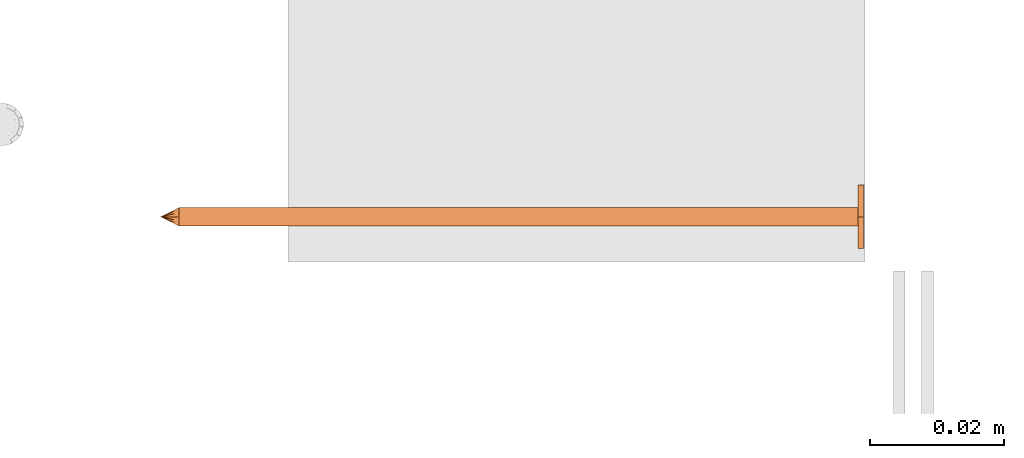
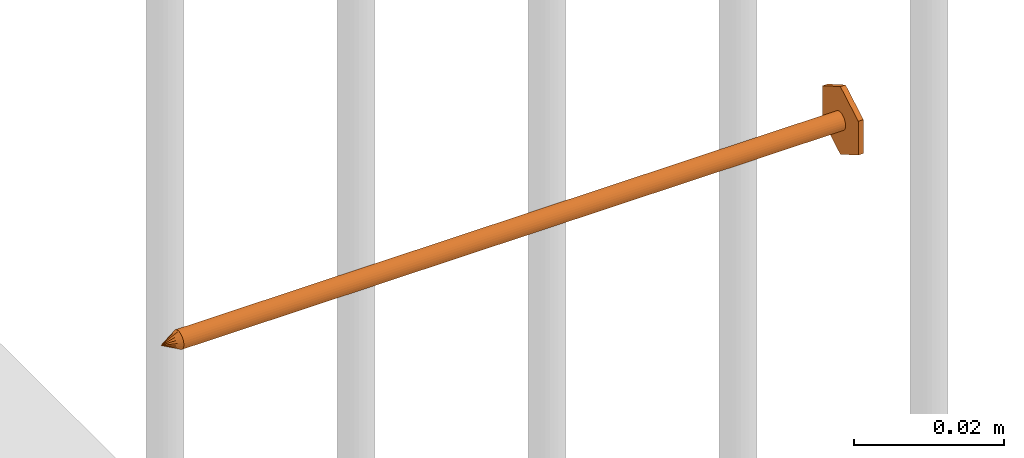
# One storey, part 22 of 44: 1 proxy.
"""IFC4 building model written with IfcOpenShell, lengths in feet."""

from ifc_helpers import new_model, entity, si_unit, converted_unit, derived_unit, direction, frame, origin, place, context, subcontext, project, spatial, source, transform, mapped, material, type_object, type_shapes, element, save


model = new_model("IFC4")

# Units and contexts
model_context = context("Model", 3, precision=0.0001, world=origin(), true_north=direction((6.12303176911189e-17, 1.0)))
body_context = subcontext(model_context, "Body", "Model", "MODEL_VIEW")
ifc_project = project(units=[converted_unit("LENGTHUNIT", "FOOT", entity("IfcRatioMeasure", 0.3048), si_unit("LENGTHUNIT", "METRE"), dimensions=[1, 0, 0, 0, 0, 0, 0]), converted_unit("AREAUNIT", "SQUARE FOOT", entity("IfcRatioMeasure", 0.09290304), si_unit("AREAUNIT", "SQUARE_METRE"), dimensions=[2, 0, 0, 0, 0, 0, 0]), converted_unit("VOLUMEUNIT", "CUBIC FOOT", entity("IfcRatioMeasure", 0.028316846592), si_unit("VOLUMEUNIT", "CUBIC_METRE"), dimensions=[3, 0, 0, 0, 0, 0, 0]), converted_unit("PLANEANGLEUNIT", "DEGREE", entity("IfcRatioMeasure", 0.0174532925199433), si_unit("PLANEANGLEUNIT", "RADIAN"), dimensions=[0, 0, 0, 0, 0, 0, 0]), si_unit("MASSUNIT", "GRAM", prefix="KILO"), derived_unit("MASSDENSITYUNIT", [(si_unit("MASSUNIT", "GRAM", prefix="KILO"), 1), (si_unit("LENGTHUNIT", "METRE"), -3)]), derived_unit("MOMENTOFINERTIAUNIT", [(si_unit("LENGTHUNIT", "METRE"), 4)]), si_unit("TIMEUNIT", "SECOND"), si_unit("FREQUENCYUNIT", "HERTZ"), si_unit("THERMODYNAMICTEMPERATUREUNIT", "DEGREE_CELSIUS"), derived_unit("THERMALTRANSMITTANCEUNIT", [(si_unit("MASSUNIT", "GRAM", prefix="KILO"), 1), (si_unit("THERMODYNAMICTEMPERATUREUNIT", "KELVIN"), -1), (si_unit("TIMEUNIT", "SECOND"), -3)]), derived_unit("VOLUMETRICFLOWRATEUNIT", [(si_unit("LENGTHUNIT", "METRE"), 3), (si_unit("TIMEUNIT", "SECOND"), -1)]), si_unit("ELECTRICCURRENTUNIT", "AMPERE"), si_unit("ELECTRICVOLTAGEUNIT", "VOLT"), si_unit("POWERUNIT", "WATT"), si_unit("FORCEUNIT", "NEWTON"), si_unit("ILLUMINANCEUNIT", "LUX"), si_unit("LUMINOUSFLUXUNIT", "LUMEN"), si_unit("LUMINOUSINTENSITYUNIT", "CANDELA"), derived_unit("USERDEFINED", [(si_unit("MASSUNIT", "GRAM", prefix="KILO"), -1), (si_unit("LENGTHUNIT", "METRE"), -2), (si_unit("TIMEUNIT", "SECOND"), 3), (si_unit("LUMINOUSFLUXUNIT", "LUMEN"), 1)]), derived_unit("LINEARVELOCITYUNIT", [(si_unit("LENGTHUNIT", "METRE"), 1), (si_unit("TIMEUNIT", "SECOND"), -1)]), si_unit("PRESSUREUNIT", "PASCAL"), derived_unit("USERDEFINED", [(si_unit("LENGTHUNIT", "METRE"), -2), (si_unit("MASSUNIT", "GRAM", prefix="KILO"), 1), (si_unit("TIMEUNIT", "SECOND"), -2)]), derived_unit("LINEARFORCEUNIT", [(si_unit("MASSUNIT", "GRAM", prefix="KILO"), 1), (si_unit("LENGTHUNIT", "METRE"), 1), (si_unit("TIMEUNIT", "SECOND"), -2), (si_unit("LENGTHUNIT", "METRE"), -1)]), derived_unit("PLANARFORCEUNIT", [(si_unit("MASSUNIT", "GRAM", prefix="KILO"), 1), (si_unit("LENGTHUNIT", "METRE"), 1), (si_unit("TIMEUNIT", "SECOND"), -2), (si_unit("LENGTHUNIT", "METRE"), -2)])], contexts=[model_context])

# Site, building, storey
site_placement = place(None, origin())
site = spatial("IfcSite", under=ifc_project, at=site_placement, CompositionType="ELEMENT")
building_placement = place(site_placement, origin())
building = spatial("IfcBuilding", under=site, at=building_placement, CompositionType="ELEMENT")
storey_placement = place(building_placement, origin())
storey = spatial("IfcBuildingStorey", under=building, at=storey_placement, CompositionType="ELEMENT", Elevation=0.0)

# Proxy
ifc_material = material(Category="Materials")
building_element_proxy_type = type_object("IfcBuildingElementProxyType", PredefinedType="NOTDEFINED", material=ifc_material)
cartesian_point_1 = entity("IfcCartesianPoint", [0.0, -0.00455729166677942, -0.333333333333231])
vertex_point_1 = entity("IfcVertexPoint", cartesian_point_1)
cartesian_point_2 = entity("IfcCartesianPoint", [0.0, 0.00455729166667798, -0.333333333333232])
vertex_point_2 = entity("IfcVertexPoint", cartesian_point_2)
cartesian_point_3 = entity("IfcCartesianPoint", [0.0, 0.0, -0.333333333333232])
ifc_direction_1 = entity("IfcDirection", [0.0, 0.0, 1.0])
ifc_direction_2 = entity("IfcDirection", [0.0, 1.0, 0.0])
edge_curve_1 = entity("IfcEdgeCurve", vertex_point_1, vertex_point_2, entity("IfcTrimmedCurve", entity("IfcCircle", entity("IfcAxis2Placement3D", cartesian_point_3, ifc_direction_1, ifc_direction_2), 0.0045572916667287), [cartesian_point_1], [cartesian_point_2], True, "CARTESIAN"), True)
vertex_point_3 = entity("IfcVertexPoint", cartesian_point_3)
ifc_direction_3 = entity("IfcDirection", [0.0, -1.0, 0.0])
edge_curve_2 = entity("IfcEdgeCurve", vertex_point_2, vertex_point_3, entity("IfcTrimmedCurve", entity("IfcLine", cartesian_point_2, entity("IfcVector", ifc_direction_3, 1.0)), [cartesian_point_2], [cartesian_point_3], True, "CARTESIAN"), True)
edge_curve_3 = entity("IfcEdgeCurve", vertex_point_3, vertex_point_1, entity("IfcTrimmedCurve", entity("IfcLine", cartesian_point_3, entity("IfcVector", ifc_direction_3, 1.0)), [cartesian_point_3], [cartesian_point_1], True, "CARTESIAN"), True)
edge_curve_4 = entity("IfcEdgeCurve", vertex_point_2, vertex_point_1, entity("IfcTrimmedCurve", entity("IfcCircle", entity("IfcAxis2Placement3D", cartesian_point_3, ifc_direction_1, ifc_direction_2), 0.0045572916667287), [cartesian_point_2], [cartesian_point_1], True, "CARTESIAN"), True)
cartesian_point_4 = entity("IfcCartesianPoint", [0.0, 0.0, -0.342447916666333])
vertex_point_4 = entity("IfcVertexPoint", cartesian_point_4)
edge_curve_5 = entity("IfcEdgeCurve", vertex_point_4, vertex_point_2, entity("IfcTrimmedCurve", entity("IfcLine", cartesian_point_4, entity("IfcVector", entity("IfcDirection", [0.0, 0.447213595514596, 0.894427190992597]), 1.0)), [cartesian_point_4], [cartesian_point_2], True, "CARTESIAN"), True)
edge_curve_6 = entity("IfcEdgeCurve", vertex_point_1, vertex_point_4, entity("IfcTrimmedCurve", entity("IfcLine", cartesian_point_1, entity("IfcVector", entity("IfcDirection", [0.0, 0.447213595514579, -0.894427190992605]), 1.0)), [cartesian_point_1], [cartesian_point_4], True, "CARTESIAN"), True)
cartesian_point_5 = entity("IfcCartesianPoint", [-0.00455729166669724, 0.0, -0.333333333333231])
cartesian_point_6 = entity("IfcCartesianPoint", [0.0, 0.0, -0.338202184590857])
ifc_direction_4 = entity("IfcDirection", [0.0, 0.0, -1.0])
cartesian_point_7 = entity("IfcCartesianPoint", [-0.0156249999999625, 0.00902109795594613, 0.00260416666704037])
vertex_point_5 = entity("IfcVertexPoint", cartesian_point_7)
cartesian_point_8 = entity("IfcCartesianPoint", [-0.0156249999999625, -0.0090210979562493, 0.00260416666704046])
vertex_point_6 = entity("IfcVertexPoint", cartesian_point_8)
ifc_direction_5 = entity("IfcDirection", [0.0, -1.0, 0.0])
edge_curve_7 = entity("IfcEdgeCurve", vertex_point_5, vertex_point_6, entity("IfcTrimmedCurve", entity("IfcLine", cartesian_point_7, entity("IfcVector", ifc_direction_5, 1.0)), [cartesian_point_7], [cartesian_point_8], True, "CARTESIAN"), True)
cartesian_point_9 = entity("IfcCartesianPoint", [0.0, -0.0180421959123274, 0.0026041666670405])
vertex_point_7 = entity("IfcVertexPoint", cartesian_point_9)
edge_curve_8 = entity("IfcEdgeCurve", vertex_point_6, vertex_point_7, entity("IfcTrimmedCurve", entity("IfcLine", cartesian_point_8, entity("IfcVector", entity("IfcDirection", [0.866025403784438, -0.500000000000001, 0.0]), 1.0)), [cartesian_point_8], [cartesian_point_9], True, "CARTESIAN"), True)
cartesian_point_10 = entity("IfcCartesianPoint", [0.0156250000000786, -0.00902109795620598, 0.00260416666704046])
vertex_point_8 = entity("IfcVertexPoint", cartesian_point_10)
edge_curve_9 = entity("IfcEdgeCurve", vertex_point_7, vertex_point_8, entity("IfcTrimmedCurve", entity("IfcLine", cartesian_point_9, entity("IfcVector", entity("IfcDirection", [0.86602540378444, 0.499999999999998, 0.0]), 1.0)), [cartesian_point_9], [cartesian_point_10], True, "CARTESIAN"), True)
cartesian_point_11 = entity("IfcCartesianPoint", [0.0156250000000786, 0.00902109795590273, 0.00260416666704037])
vertex_point_9 = entity("IfcVertexPoint", cartesian_point_11)
ifc_direction_6 = entity("IfcDirection", [0.0, 1.0, 0.0])
edge_curve_10 = entity("IfcEdgeCurve", vertex_point_8, vertex_point_9, entity("IfcTrimmedCurve", entity("IfcLine", cartesian_point_10, entity("IfcVector", ifc_direction_6, 1.0)), [cartesian_point_10], [cartesian_point_11], True, "CARTESIAN"), True)
cartesian_point_12 = entity("IfcCartesianPoint", [0.0, 0.0180421959120243, 0.00260416666704032])
vertex_point_10 = entity("IfcVertexPoint", cartesian_point_12)
edge_curve_11 = entity("IfcEdgeCurve", vertex_point_9, vertex_point_10, entity("IfcTrimmedCurve", entity("IfcLine", cartesian_point_11, entity("IfcVector", entity("IfcDirection", [-0.866025403784437, 0.500000000000003, 0.0]), 1.0)), [cartesian_point_11], [cartesian_point_12], True, "CARTESIAN"), True)
edge_curve_12 = entity("IfcEdgeCurve", vertex_point_10, vertex_point_5, entity("IfcTrimmedCurve", entity("IfcLine", cartesian_point_12, entity("IfcVector", entity("IfcDirection", [-0.866025403784438, -0.500000000000001, 0.0]), 1.0)), [cartesian_point_12], [cartesian_point_7], True, "CARTESIAN"), True)
ifc_direction_7 = entity("IfcDirection", [0.0, 0.0, 1.0])
cartesian_point_13 = entity("IfcCartesianPoint", [-0.0156249999999625, 0.00902109795594612, 0.0])
vertex_point_11 = entity("IfcVertexPoint", cartesian_point_13)
cartesian_point_14 = entity("IfcCartesianPoint", [0.0, 0.0180421959120242, 0.0])
vertex_point_12 = entity("IfcVertexPoint", cartesian_point_14)
edge_curve_13 = entity("IfcEdgeCurve", vertex_point_11, vertex_point_12, entity("IfcTrimmedCurve", entity("IfcLine", cartesian_point_13, entity("IfcVector", entity("IfcDirection", [0.866025403784438, 0.500000000000001, 0.0]), 1.0)), [cartesian_point_13], [cartesian_point_14], True, "CARTESIAN"), True)
cartesian_point_15 = entity("IfcCartesianPoint", [0.0156250000000786, 0.00902109795590272, 0.0])
vertex_point_13 = entity("IfcVertexPoint", cartesian_point_15)
edge_curve_14 = entity("IfcEdgeCurve", vertex_point_12, vertex_point_13, entity("IfcTrimmedCurve", entity("IfcLine", cartesian_point_14, entity("IfcVector", entity("IfcDirection", [0.866025403784437, -0.500000000000003, 0.0]), 1.0)), [cartesian_point_14], [cartesian_point_15], True, "CARTESIAN"), True)
cartesian_point_16 = entity("IfcCartesianPoint", [0.0156250000000786, -0.00902109795620599, 0.0])
vertex_point_14 = entity("IfcVertexPoint", cartesian_point_16)
edge_curve_15 = entity("IfcEdgeCurve", vertex_point_13, vertex_point_14, entity("IfcTrimmedCurve", entity("IfcLine", cartesian_point_15, entity("IfcVector", ifc_direction_5, 1.0)), [cartesian_point_15], [cartesian_point_16], True, "CARTESIAN"), True)
cartesian_point_17 = entity("IfcCartesianPoint", [0.0, -0.0180421959123274, 0.0])
vertex_point_15 = entity("IfcVertexPoint", cartesian_point_17)
edge_curve_16 = entity("IfcEdgeCurve", vertex_point_14, vertex_point_15, entity("IfcTrimmedCurve", entity("IfcLine", cartesian_point_16, entity("IfcVector", entity("IfcDirection", [-0.86602540378444, -0.499999999999998, 0.0]), 1.0)), [cartesian_point_16], [cartesian_point_17], True, "CARTESIAN"), True)
cartesian_point_18 = entity("IfcCartesianPoint", [-0.0156249999999625, -0.00902109795624931, 0.0])
vertex_point_16 = entity("IfcVertexPoint", cartesian_point_18)
edge_curve_17 = entity("IfcEdgeCurve", vertex_point_15, vertex_point_16, entity("IfcTrimmedCurve", entity("IfcLine", cartesian_point_17, entity("IfcVector", entity("IfcDirection", [-0.866025403784438, 0.500000000000001, 0.0]), 1.0)), [cartesian_point_17], [cartesian_point_18], True, "CARTESIAN"), True)
edge_curve_18 = entity("IfcEdgeCurve", vertex_point_16, vertex_point_11, entity("IfcTrimmedCurve", entity("IfcLine", cartesian_point_18, entity("IfcVector", ifc_direction_6, 1.0)), [cartesian_point_18], [cartesian_point_13], True, "CARTESIAN"), True)
ifc_direction_8 = entity("IfcDirection", [0.0, 0.0, -1.0])
edge_curve_19 = entity("IfcEdgeCurve", vertex_point_5, vertex_point_11, entity("IfcTrimmedCurve", entity("IfcLine", cartesian_point_7, entity("IfcVector", ifc_direction_8, 1.0)), [cartesian_point_7], [cartesian_point_13], True, "CARTESIAN"), True)
edge_curve_20 = entity("IfcEdgeCurve", vertex_point_16, vertex_point_6, entity("IfcTrimmedCurve", entity("IfcLine", cartesian_point_8, entity("IfcVector", ifc_direction_7, 1.0)), [cartesian_point_18], [cartesian_point_8], True, "CARTESIAN"), True)
edge_curve_21 = entity("IfcEdgeCurve", vertex_point_15, vertex_point_7, entity("IfcTrimmedCurve", entity("IfcLine", cartesian_point_9, entity("IfcVector", ifc_direction_7, 1.0)), [cartesian_point_17], [cartesian_point_9], True, "CARTESIAN"), True)
edge_curve_22 = entity("IfcEdgeCurve", vertex_point_14, vertex_point_8, entity("IfcTrimmedCurve", entity("IfcLine", cartesian_point_10, entity("IfcVector", ifc_direction_7, 1.0)), [cartesian_point_16], [cartesian_point_10], True, "CARTESIAN"), True)
edge_curve_23 = entity("IfcEdgeCurve", vertex_point_13, vertex_point_9, entity("IfcTrimmedCurve", entity("IfcLine", cartesian_point_11, entity("IfcVector", ifc_direction_7, 1.0)), [cartesian_point_15], [cartesian_point_11], True, "CARTESIAN"), True)
edge_curve_24 = entity("IfcEdgeCurve", vertex_point_12, vertex_point_10, entity("IfcTrimmedCurve", entity("IfcLine", cartesian_point_12, entity("IfcVector", ifc_direction_7, 1.0)), [cartesian_point_14], [cartesian_point_12], True, "CARTESIAN"), True)
cartesian_point_19 = entity("IfcCartesianPoint", [0.0, -0.00455729166682102, 0.0])
vertex_point_17 = entity("IfcVertexPoint", cartesian_point_19)
cartesian_point_20 = entity("IfcCartesianPoint", [0.0, 0.00455729166651231, 0.0])
vertex_point_18 = entity("IfcVertexPoint", cartesian_point_20)
cartesian_point_21 = entity("IfcCartesianPoint", [0.0, 0.0, 0.0])
ifc_direction_9 = entity("IfcDirection", [0.0, 0.0, 1.0])
ifc_direction_10 = entity("IfcDirection", [0.0, 1.0, 0.0])
edge_curve_25 = entity("IfcEdgeCurve", vertex_point_17, vertex_point_18, entity("IfcTrimmedCurve", entity("IfcCircle", entity("IfcAxis2Placement3D", cartesian_point_21, ifc_direction_9, ifc_direction_10), 0.00455729166666667), [cartesian_point_19], [cartesian_point_20], True, "CARTESIAN"), True)
edge_curve_26 = entity("IfcEdgeCurve", vertex_point_18, vertex_point_17, entity("IfcTrimmedCurve", entity("IfcCircle", entity("IfcAxis2Placement3D", cartesian_point_21, ifc_direction_9, ifc_direction_10), 0.00455729166666667), [cartesian_point_20], [cartesian_point_19], True, "CARTESIAN"), True)
cartesian_point_22 = entity("IfcCartesianPoint", [0.0, -0.00455729166682389, -0.333333333333339])
vertex_point_19 = entity("IfcVertexPoint", cartesian_point_22)
cartesian_point_23 = entity("IfcCartesianPoint", [0.0, 0.00455729166650944, -0.333333333333339])
vertex_point_20 = entity("IfcVertexPoint", cartesian_point_23)
cartesian_point_24 = entity("IfcCartesianPoint", [0.0, 0.0, -0.333333333333339])
ifc_direction_11 = entity("IfcDirection", [0.0, 0.0, -1.0])
edge_curve_27 = entity("IfcEdgeCurve", vertex_point_19, vertex_point_20, entity("IfcTrimmedCurve", entity("IfcCircle", entity("IfcAxis2Placement3D", cartesian_point_24, ifc_direction_11, ifc_direction_10), 0.00455729166666667), [cartesian_point_22], [cartesian_point_23], True, "CARTESIAN"), True)
edge_curve_28 = entity("IfcEdgeCurve", vertex_point_20, vertex_point_19, entity("IfcTrimmedCurve", entity("IfcCircle", entity("IfcAxis2Placement3D", cartesian_point_24, ifc_direction_11, ifc_direction_10), 0.00455729166666667), [cartesian_point_23], [cartesian_point_22], True, "CARTESIAN"), True)
edge_curve_29 = entity("IfcEdgeCurve", vertex_point_17, vertex_point_19, entity("IfcTrimmedCurve", entity("IfcLine", cartesian_point_19, entity("IfcVector", ifc_direction_11, 1.0)), [cartesian_point_19], [cartesian_point_22], True, "CARTESIAN"), True)
edge_curve_30 = entity("IfcEdgeCurve", vertex_point_20, vertex_point_18, entity("IfcTrimmedCurve", entity("IfcLine", cartesian_point_20, entity("IfcVector", ifc_direction_9, 1.0)), [cartesian_point_23], [cartesian_point_20], True, "CARTESIAN"), True)
shared_shape = source(origin(), body_context, "Body", "AdvancedBrep", [
    entity("IfcAdvancedBrep", entity("IfcClosedShell", [entity("IfcAdvancedFace", [entity("IfcFaceOuterBound", entity("IfcEdgeLoop", [entity("IfcOrientedEdge", None, None, edge_curve_1, True), entity("IfcOrientedEdge", None, None, edge_curve_2, True), entity("IfcOrientedEdge", None, None, edge_curve_3, True)]), True)], entity("IfcPlane", entity("IfcAxis2Placement3D", cartesian_point_3, ifc_direction_1, ifc_direction_2)), True), entity("IfcAdvancedFace", [entity("IfcFaceOuterBound", entity("IfcEdgeLoop", [entity("IfcOrientedEdge", None, None, edge_curve_4, True), entity("IfcOrientedEdge", None, None, edge_curve_3, False), entity("IfcOrientedEdge", None, None, edge_curve_2, False)]), True)], entity("IfcPlane", entity("IfcAxis2Placement3D", cartesian_point_3, ifc_direction_1, ifc_direction_2)), True), entity("IfcAdvancedFace", [entity("IfcFaceOuterBound", entity("IfcEdgeLoop", [entity("IfcOrientedEdge", None, None, edge_curve_5, True), entity("IfcOrientedEdge", None, None, edge_curve_1, False), entity("IfcOrientedEdge", None, None, edge_curve_6, True)]), True)], entity("IfcSurfaceOfRevolution", entity("IfcArbitraryOpenProfileDef", "CURVE", None, entity("IfcTrimmedCurve", entity("IfcLine", cartesian_point_4, entity("IfcVector", entity("IfcDirection", [0.447213595514577, 0.0, -0.894427190992606]), 1.0)), [cartesian_point_5], [cartesian_point_4], True, "CARTESIAN")), None, entity("IfcAxis1Placement", cartesian_point_6, ifc_direction_4)), True), entity("IfcAdvancedFace", [entity("IfcFaceOuterBound", entity("IfcEdgeLoop", [entity("IfcOrientedEdge", None, None, edge_curve_6, False), entity("IfcOrientedEdge", None, None, edge_curve_4, False), entity("IfcOrientedEdge", None, None, edge_curve_5, False)]), True)], entity("IfcSurfaceOfRevolution", entity("IfcArbitraryOpenProfileDef", "CURVE", None, entity("IfcTrimmedCurve", entity("IfcLine", cartesian_point_4, entity("IfcVector", entity("IfcDirection", [0.447213595514577, 0.0, -0.894427190992606]), 1.0)), [cartesian_point_5], [cartesian_point_4], True, "CARTESIAN")), None, entity("IfcAxis1Placement", cartesian_point_6, ifc_direction_4)), True)])),
    entity("IfcAdvancedBrep", entity("IfcClosedShell", [entity("IfcAdvancedFace", [entity("IfcFaceOuterBound", entity("IfcEdgeLoop", [entity("IfcOrientedEdge", None, None, edge_curve_7, True), entity("IfcOrientedEdge", None, None, edge_curve_8, True), entity("IfcOrientedEdge", None, None, edge_curve_9, True), entity("IfcOrientedEdge", None, None, edge_curve_10, True), entity("IfcOrientedEdge", None, None, edge_curve_11, True), entity("IfcOrientedEdge", None, None, edge_curve_12, True)]), True)], entity("IfcPlane", entity("IfcAxis2Placement3D", cartesian_point_7, ifc_direction_7, ifc_direction_5)), True), entity("IfcAdvancedFace", [entity("IfcFaceOuterBound", entity("IfcEdgeLoop", [entity("IfcOrientedEdge", None, None, edge_curve_13, True), entity("IfcOrientedEdge", None, None, edge_curve_14, True), entity("IfcOrientedEdge", None, None, edge_curve_15, True), entity("IfcOrientedEdge", None, None, edge_curve_16, True), entity("IfcOrientedEdge", None, None, edge_curve_17, True), entity("IfcOrientedEdge", None, None, edge_curve_18, True)]), True)], entity("IfcPlane", entity("IfcAxis2Placement3D", cartesian_point_13, ifc_direction_8, ifc_direction_6)), True), entity("IfcAdvancedFace", [entity("IfcFaceOuterBound", entity("IfcEdgeLoop", [entity("IfcOrientedEdge", None, None, edge_curve_7, False), entity("IfcOrientedEdge", None, None, edge_curve_19, True), entity("IfcOrientedEdge", None, None, edge_curve_18, False), entity("IfcOrientedEdge", None, None, edge_curve_20, True)]), True)], entity("IfcPlane", entity("IfcAxis2Placement3D", cartesian_point_7, entity("IfcDirection", [-1.0, 0.0, 0.0]), ifc_direction_8)), True), entity("IfcAdvancedFace", [entity("IfcFaceOuterBound", entity("IfcEdgeLoop", [entity("IfcOrientedEdge", None, None, edge_curve_8, False), entity("IfcOrientedEdge", None, None, edge_curve_20, False), entity("IfcOrientedEdge", None, None, edge_curve_17, False), entity("IfcOrientedEdge", None, None, edge_curve_21, True)]), True)], entity("IfcPlane", entity("IfcAxis2Placement3D", cartesian_point_8, entity("IfcDirection", [-0.500000000000001, -0.866025403784438, 0.0]), ifc_direction_8)), True), entity("IfcAdvancedFace", [entity("IfcFaceOuterBound", entity("IfcEdgeLoop", [entity("IfcOrientedEdge", None, None, edge_curve_9, False), entity("IfcOrientedEdge", None, None, edge_curve_21, False), entity("IfcOrientedEdge", None, None, edge_curve_16, False), entity("IfcOrientedEdge", None, None, edge_curve_22, True)]), True)], entity("IfcPlane", entity("IfcAxis2Placement3D", cartesian_point_9, entity("IfcDirection", [0.499999999999998, -0.86602540378444, 0.0]), ifc_direction_8)), True), entity("IfcAdvancedFace", [entity("IfcFaceOuterBound", entity("IfcEdgeLoop", [entity("IfcOrientedEdge", None, None, edge_curve_10, False), entity("IfcOrientedEdge", None, None, edge_curve_22, False), entity("IfcOrientedEdge", None, None, edge_curve_15, False), entity("IfcOrientedEdge", None, None, edge_curve_23, True)]), True)], entity("IfcPlane", entity("IfcAxis2Placement3D", cartesian_point_10, entity("IfcDirection", [1.0, 0.0, 0.0]), ifc_direction_8)), True), entity("IfcAdvancedFace", [entity("IfcFaceOuterBound", entity("IfcEdgeLoop", [entity("IfcOrientedEdge", None, None, edge_curve_11, False), entity("IfcOrientedEdge", None, None, edge_curve_23, False), entity("IfcOrientedEdge", None, None, edge_curve_14, False), entity("IfcOrientedEdge", None, None, edge_curve_24, True)]), True)], entity("IfcPlane", entity("IfcAxis2Placement3D", cartesian_point_11, entity("IfcDirection", [0.500000000000003, 0.866025403784437, 0.0]), ifc_direction_8)), True), entity("IfcAdvancedFace", [entity("IfcFaceOuterBound", entity("IfcEdgeLoop", [entity("IfcOrientedEdge", None, None, edge_curve_12, False), entity("IfcOrientedEdge", None, None, edge_curve_24, False), entity("IfcOrientedEdge", None, None, edge_curve_13, False), entity("IfcOrientedEdge", None, None, edge_curve_19, False)]), True)], entity("IfcPlane", entity("IfcAxis2Placement3D", cartesian_point_12, entity("IfcDirection", [-0.500000000000001, 0.866025403784438, 0.0]), ifc_direction_8)), True)])),
    entity("IfcAdvancedBrep", entity("IfcClosedShell", [entity("IfcAdvancedFace", [entity("IfcFaceOuterBound", entity("IfcEdgeLoop", [entity("IfcOrientedEdge", None, None, edge_curve_25, True), entity("IfcOrientedEdge", None, None, edge_curve_26, True)]), True)], entity("IfcPlane", entity("IfcAxis2Placement3D", cartesian_point_20, ifc_direction_9, entity("IfcDirection", [-1.0, 0.0, 0.0]))), True), entity("IfcAdvancedFace", [entity("IfcFaceOuterBound", entity("IfcEdgeLoop", [entity("IfcOrientedEdge", None, None, edge_curve_27, True), entity("IfcOrientedEdge", None, None, edge_curve_28, True)]), True)], entity("IfcPlane", entity("IfcAxis2Placement3D", cartesian_point_23, ifc_direction_11, entity("IfcDirection", [1.0, 0.0, 0.0]))), True), entity("IfcAdvancedFace", [entity("IfcFaceOuterBound", entity("IfcEdgeLoop", [entity("IfcOrientedEdge", None, None, edge_curve_25, False), entity("IfcOrientedEdge", None, None, edge_curve_29, True), entity("IfcOrientedEdge", None, None, edge_curve_28, False), entity("IfcOrientedEdge", None, None, edge_curve_30, True)]), True)], entity("IfcCylindricalSurface", entity("IfcAxis2Placement3D", cartesian_point_24, ifc_direction_9, ifc_direction_10), 0.00455729166666667), True), entity("IfcAdvancedFace", [entity("IfcFaceOuterBound", entity("IfcEdgeLoop", [entity("IfcOrientedEdge", None, None, edge_curve_26, False), entity("IfcOrientedEdge", None, None, edge_curve_30, False), entity("IfcOrientedEdge", None, None, edge_curve_27, False), entity("IfcOrientedEdge", None, None, edge_curve_29, False)]), True)], entity("IfcCylindricalSurface", entity("IfcAxis2Placement3D", cartesian_point_24, ifc_direction_9, ifc_direction_10), 0.00455729166666667), True)])),
])
type_shapes(building_element_proxy_type, [shared_shape])
proxy_placement = place(storey_placement, frame((1494.28883103225, 3.06823839265228, 10.4899253669743), z_axis=(1.0, 0.0, 0.0), x_axis=(0.0, 1.0, 0.0)))
element("IfcBuildingElementProxy", 1, at=proxy_placement, inside=storey, type_object=building_element_proxy_type, material=ifc_material, PredefinedType="NOTDEFINED", context=body_context, shape_type="MappedRepresentation", body=[
    mapped(shared_shape, transform((0.0, 0.0, 0.0), scale=1.0)),
])

save(model, "model.ifc")
